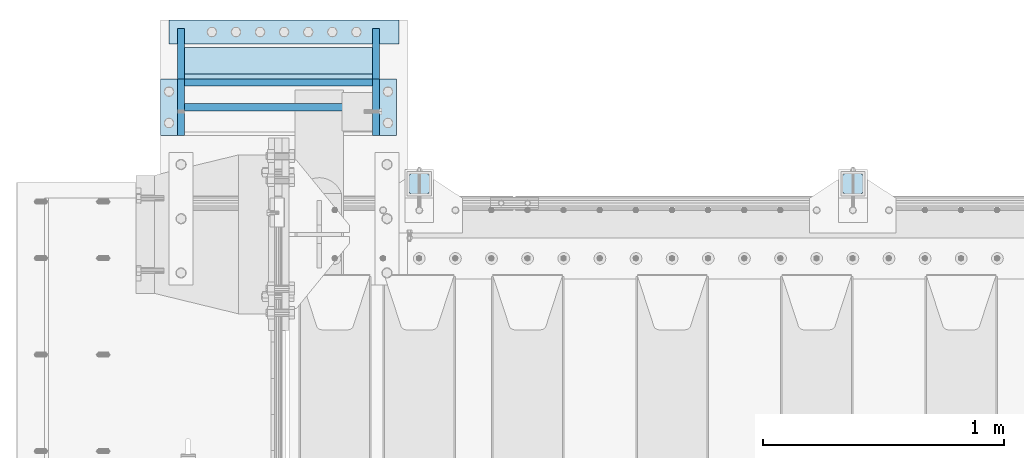
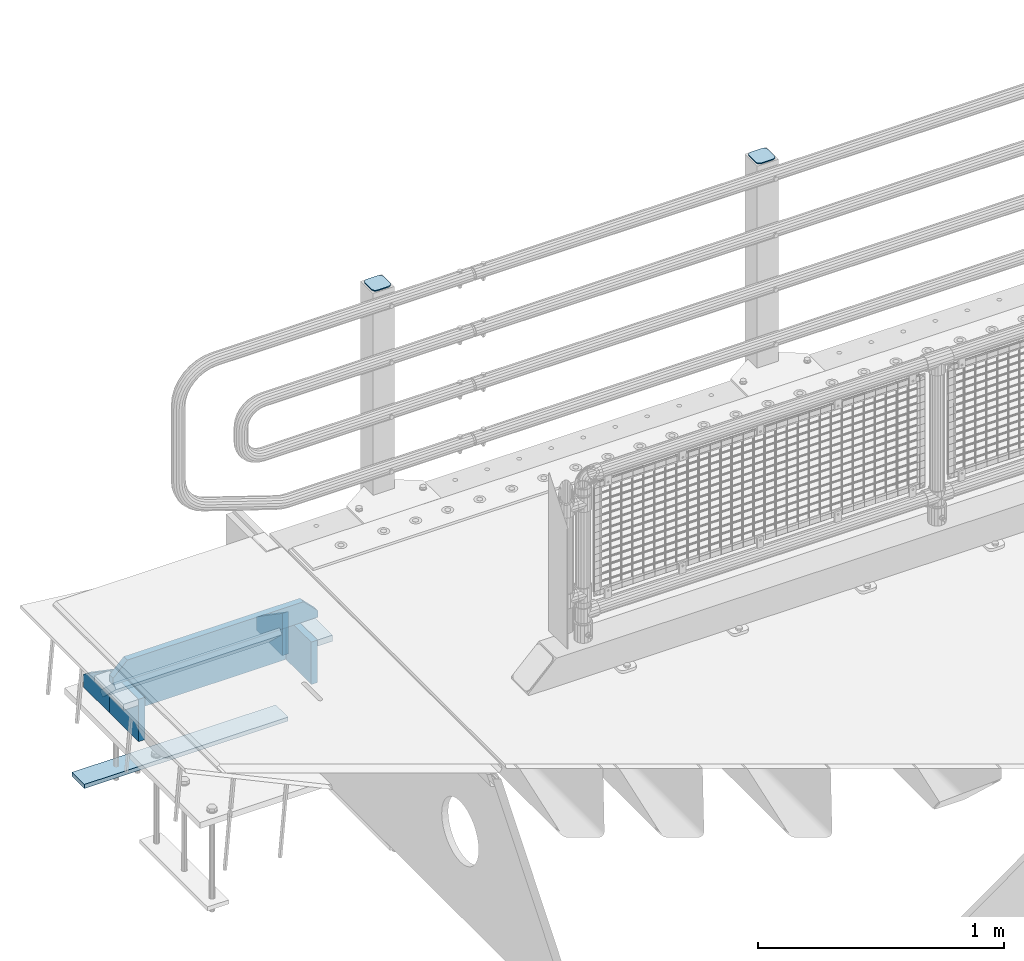
# One storey, part 195 of 219: 12 plates.
"""IFC2X3 building model written with IfcOpenShell, lengths in millimetres."""

import ifcopenshell
import ifcopenshell.guid

model = None  # the IFC model being written
_history = None  # IfcOwnerHistory: only IFC2X3 demands one
_inside = {}  # id of a spatial element -> (the spatial element, [elements in it])
_under = {}  # id of a project, library or spatial element -> (it, [spatial elements below it])
_declared = {}  # id of a project -> (the project, [libraries it declares])
_typed = {}  # id of a type object -> (the type object, [elements of that type])
_made_of = {}  # id of a material, layer set ... -> (it, [elements and type objects made of it])


def new_model(schema):
    """Start an empty IFC model of exactly this schema.

    Asked for "IFC4X3", IfcOpenShell would pick the latest addendum, in which some entities
    have other attributes; the version numbers below select the first issue.
    IFC2X3 requires an IfcOwnerHistory on every rooted entity: one is made here for all.
    """
    global model, _history
    if schema == "IFC4X3":
        model = ifcopenshell.file(schema_version=(4, 3, 0, 0))
    else:
        model = ifcopenshell.file(schema=schema)
    _inside.clear()
    _under.clear()
    _declared.clear()
    _typed.clear()
    _made_of.clear()
    _history = None
    if model.schema == "IFC2X3":
        org = make("IfcOrganization", Name="unknown")
        user = make(
            "IfcPersonAndOrganization",
            ThePerson=make("IfcPerson", FamilyName="unknown"),
            TheOrganization=org,
        )
        app = make(
            "IfcApplication",
            ApplicationDeveloper=org,
            Version="unknown",
            ApplicationFullName="unknown",
            ApplicationIdentifier="unknown",
        )
        _history = make(
            "IfcOwnerHistory",
            OwningUser=user,
            OwningApplication=app,
            ChangeAction="ADDED",
            CreationDate=0,
        )
    return model


def make(cls, **values):
    """One entity of the class cls with the attributes given. An attribute that is None is left unset."""
    return model.create_entity(
        cls, **{name: value for name, value in values.items() if value is not None}
    )


def rooted(cls, **values):
    """An entity with a GlobalId (a new one), such as an element, a storey or a relation."""
    return make(cls, GlobalId=ifcopenshell.guid.new(), OwnerHistory=_history, **values)


def si_unit(unit_type, name, prefix=None):
    """IfcSIUnit, for example si_unit("LENGTHUNIT", "METRE", prefix="MILLI")."""
    return make("IfcSIUnit", UnitType=unit_type, Prefix=prefix, Name=name)


def assignment(units):
    """IfcUnitAssignment: the units of a project."""
    return None if units is None else make("IfcUnitAssignment", Units=units)


def point(xyz):
    """IfcCartesianPoint."""
    return None if xyz is None else make("IfcCartesianPoint", Coordinates=xyz)


def direction(xyz):
    """IfcDirection."""
    return None if xyz is None else make("IfcDirection", DirectionRatios=xyz)


def frame(location, z_axis=None, x_axis=None):
    """IfcAxis2Placement3D, a coordinate frame: its origin and axes. An axis left out is left unset."""
    return make(
        "IfcAxis2Placement3D",
        Location=point(location),
        Axis=direction(z_axis),
        RefDirection=direction(x_axis),
    )


def origin_with_axes():
    """The frame at (0, 0, 0) with the z axis (0, 0, 1) and the x axis (1, 0, 0) written out."""
    return frame((0.0, 0.0, 0.0), z_axis=(0.0, 0.0, 1.0), x_axis=(1.0, 0.0, 0.0))


def place(relative_to, where):
    """IfcLocalPlacement: puts the frame where relative to a parent placement (None: the world)."""
    return make(
        "IfcLocalPlacement", PlacementRelTo=relative_to, RelativePlacement=where
    )


def context(
    kind, dimensions, precision=None, world=None, true_north=None, identifier=None
):
    """IfcGeometricRepresentationContext, for example the 3D "Model" context."""
    return make(
        "IfcGeometricRepresentationContext",
        ContextIdentifier=identifier,
        ContextType=kind,
        CoordinateSpaceDimension=dimensions,
        Precision=precision,
        WorldCoordinateSystem=world,
        TrueNorth=true_north,
    )


def subcontext(parent, identifier, kind, view, scale=None):
    """IfcGeometricRepresentationSubContext, for example "Body" below "Model"."""
    return make(
        "IfcGeometricRepresentationSubContext",
        ContextIdentifier=identifier,
        ContextType=kind,
        ParentContext=parent,
        TargetScale=scale,
        TargetView=view,
    )


def project(units=None, contexts=None):
    """IfcProject with its units and contexts."""
    return rooted(
        "IfcProject",
        Name="project",
        RepresentationContexts=contexts,
        UnitsInContext=assignment(units),
    )


def spatial(cls, under=None, at=None, **own):
    """A site, building, storey or space (cls), placed at a placement, below another one or the project."""
    s = rooted(cls, ObjectPlacement=at, **own)
    if under is not None:
        _under.setdefault(under.id(), (under, []))[1].append(s)
    return s


def faces_of(points, faces, orient=None, outer=None):
    """IfcFace entities. A face is a list of loops; a loop is a list of indices into points, from 0.

    orient and outer hold one flag for each loop. By default every Orientation is true, the
    first loop of a face is its IfcFaceOuterBound and the others are IfcFaceBound.
    """
    made = []
    for i, loops in enumerate(faces):
        bounds = []
        for j, loop in enumerate(loops):
            is_outer = j == 0 if outer is None else outer[i][j]
            bounds.append(
                make(
                    "IfcFaceOuterBound" if is_outer else "IfcFaceBound",
                    Bound=make("IfcPolyLoop", Polygon=[points[k] for k in loop]),
                    Orientation=True if orient is None else orient[i][j],
                )
            )
        made.append(make("IfcFace", Bounds=bounds))
    return made


def faceted_brep(points, faces, orient=None, outer=None, voids=None):
    """IfcFacetedBrep: a solid bounded by flat faces; with voids (closed shells), ...WithVoids."""
    shared = [point(p) for p in points]
    hull = make("IfcClosedShell", CfsFaces=faces_of(shared, faces, orient, outer))
    if voids is None:
        return make("IfcFacetedBrep", Outer=hull)
    return make(
        "IfcFacetedBrepWithVoids",
        Outer=hull,
        Voids=[
            make(cls, CfsFaces=faces_of(shared, fs, o, b)) for cls, fs, o, b in voids
        ],
    )


def shape(context_of_items, identifier, shape_type, items):
    """IfcShapeRepresentation: the items that make up one representation, for example the "Body"."""
    return make(
        "IfcShapeRepresentation",
        ContextOfItems=context_of_items,
        RepresentationIdentifier=identifier,
        RepresentationType=shape_type,
        Items=items,
    )


def material(Name=None, Category=None):
    """IfcMaterial."""
    return make("IfcMaterial", Name=Name, Category=Category)


def made_of(thing, what):
    """Note that an element or type object is made of a material, layer set ...; save() writes the relation."""
    if what is not None:
        _made_of.setdefault(what.id(), (what, []))[1].append(thing)
    return thing


def type_object(cls, material=None, **own):
    """A type object (cls), such as IfcWallType, which elements share."""
    return made_of(rooted(cls, **own), material)


def element(
    cls,
    number,
    at=None,
    inside=None,
    cuts=None,
    type_object=None,
    material=None,
    context=None,
    identifier="Body",
    shape_type=None,
    held_by="IfcProductDefinitionShape",
    body=None,
    shapes=None,
    **own,
):
    """One element of the class cls, such as IfcWall. Its Tag is "e" and its number.

    at: its placement. inside: the storey or other place that contains it. cuts: it is an
    opening in that element (IfcRelVoidsElement). A single representation is given by context,
    identifier, shape_type and body (its items); several are given by shapes. held_by: the class
    of the entity that holds the representations. save() writes the other relations.
    """
    e = rooted(cls, Tag="e%d" % number, ObjectPlacement=at, **own)
    if body is not None:
        shapes = [shape(context, identifier, shape_type, body)]
    if shapes is not None:
        e.Representation = make(held_by, Representations=shapes)
    if inside is not None:
        _inside.setdefault(inside.id(), (inside, []))[1].append(e)
    if cuts is not None:
        rooted(
            "IfcRelVoidsElement", RelatingBuildingElement=cuts, RelatedOpeningElement=e
        )
    if type_object is not None:
        _typed.setdefault(type_object.id(), (type_object, []))[1].append(e)
    return made_of(e, material)


def aggregate(whole, parts):
    """IfcRelAggregates: a whole, such as a stair, and the parts it consists of."""
    return rooted("IfcRelAggregates", RelatingObject=whole, RelatedObjects=parts)


def save(model, path):
    """Write the relations noted so far, then the file.

    IfcRelAggregates (storeys below a building ...), IfcRelContainedInSpatialStructure (elements
    in a storey), IfcRelDefinesByType, IfcRelAssociatesMaterial and IfcRelDeclares: one each for
    every whole, place, type object, material and project.
    """
    for whole, parts in _under.values():
        aggregate(whole, parts)
    for where, things in _inside.values():
        rooted(
            "IfcRelContainedInSpatialStructure",
            RelatedElements=things,
            RelatingStructure=where,
        )
    for kind, things in _typed.values():
        rooted("IfcRelDefinesByType", RelatedObjects=things, RelatingType=kind)
    for what, things in _made_of.values():
        rooted("IfcRelAssociatesMaterial", RelatedObjects=things, RelatingMaterial=what)
    for by, libraries in _declared.values():
        rooted("IfcRelDeclares", RelatingContext=by, RelatedDefinitions=libraries)
    model.write(path)


model = new_model("IFC2X3")

# Units and contexts
model_context = context("Model", 3, precision=1e-05, world=origin_with_axes())
body_context = subcontext(model_context, "Body", "Model", "MODEL_VIEW")
ifc_project = project(units=[si_unit("LENGTHUNIT", "METRE", prefix="MILLI"), si_unit("AREAUNIT", "SQUARE_METRE"), si_unit("VOLUMEUNIT", "CUBIC_METRE"), si_unit("MASSUNIT", "GRAM", prefix="KILO"), si_unit("TIMEUNIT", "SECOND"), si_unit("PLANEANGLEUNIT", "RADIAN"), si_unit("SOLIDANGLEUNIT", "STERADIAN"), si_unit("THERMODYNAMICTEMPERATUREUNIT", "DEGREE_CELSIUS"), si_unit("LUMINOUSINTENSITYUNIT", "LUMEN")], contexts=[model_context])

# Site, building, storey
site_placement = place(None, origin_with_axes())
site = spatial("IfcSite", under=ifc_project, at=site_placement, CompositionType="ELEMENT")
building_placement = place(site_placement, origin_with_axes())
building = spatial("IfcBuilding", under=site, at=building_placement, Name="Standard", CompositionType="ELEMENT")
storey_placement = place(building_placement, origin_with_axes())
storey = spatial("IfcBuildingStorey", under=building, at=storey_placement, Name="Undefined", CompositionType="ELEMENT", Elevation=0.0)

# Plates
ifc_material_1 = material(Name="STEEL/S355J2")
plate_type_1 = type_object("IfcPlateType", PredefinedType="NOTDEFINED")
plate_1_placement = place(storey_placement, frame((2394.00000000013, 33166.0000000002, 1012.50000000001), z_axis=(0.0, 1.0, 0.0), x_axis=(-1.0, 0.0, 0.0)))
element("IfcPlate", 1, at=plate_1_placement, inside=storey, type_object=plate_type_1, material=ifc_material_1, context=body_context, shape_type="Brep", body=[
    faceted_brep([(0.0, -2.5, 19.0), (0.0, -2.5, 69.0), (0.0, 2.5, 69.0), (0.0, 2.5, 19.0), (0.476369668545885, -2.5, 73.2278977451715), (0.476369668545885, 2.5, 73.2278977451715), (1.88159150985484, -2.5, 77.2437910432345), (1.88159150985484, 2.5, 77.2437910432345), (4.14520183310742, -2.5, 80.8463062353185), (4.14520183310742, 2.5, 80.8463062353185), (7.15369376468334, -2.5, 83.8547981668889), (7.15369376468334, 2.5, 83.8547981668889), (10.7562089567673, -2.5, 86.118408490147), (10.7562089567673, 2.5, 86.118408490147), (14.7721022548303, -2.5, 87.5236303314523), (14.7721022548303, 2.5, 87.5236303314523), (19.0, -2.5, 88.0), (19.0, 2.5, 88.0), (69.0, -2.5, 88.0), (69.0, 2.5, 88.0), (73.2278977451697, -2.5, 87.5236303314523), (73.2278977451697, 2.5, 87.5236303314523), (77.2437910432327, -2.5, 86.118408490147), (77.2437910432327, 2.5, 86.118408490147), (80.8463062353167, -2.5, 83.8547981668889), (80.8463062353167, 2.5, 83.8547981668889), (83.8547981668926, -2.5, 80.8463062353185), (83.8547981668926, 2.5, 80.8463062353185), (86.1184084901452, -2.5, 77.2437910432345), (86.1184084901452, 2.5, 77.2437910432345), (87.5236303314541, -2.5, 73.2278977451715), (87.5236303314541, 2.5, 73.2278977451715), (88.0, -2.5, 69.0), (88.0, 2.5, 69.0), (88.0, -2.5, 19.0), (88.0, 2.5, 19.0), (87.5236303314541, -2.5, 14.7721022548285), (87.5236303314541, 2.5, 14.7721022548285), (86.1184084901452, -2.5, 10.7562089567655), (86.1184084901452, 2.5, 10.7562089567655), (83.8547981668926, -2.5, 7.15369376468152), (83.8547981668926, 2.5, 7.15369376468152), (80.8463062353167, -2.5, 4.14520183311106), (80.8463062353167, 2.5, 4.14520183311106), (77.2437910432345, -2.5, 1.88159150985302), (77.2437910432345, 2.5, 1.88159150985302), (73.2278977451697, -2.5, 0.476369668547704), (73.2278977451697, 2.5, 0.476369668547704), (69.0, -2.5, 0.0), (69.0, 2.5, 0.0), (19.0, -2.5, 0.0), (19.0, 2.5, 0.0), (14.7721022548303, -2.5, 0.476369668547704), (14.7721022548303, 2.5, 0.476369668547704), (10.7562089567673, -2.5, 1.88159150985302), (10.7562089567673, 2.5, 1.88159150985302), (7.15369376468334, -2.5, 4.14520183311106), (7.15369376468334, 2.5, 4.14520183311106), (4.14520183310742, -2.5, 7.15369376468152), (4.14520183310742, 2.5, 7.15369376468152), (1.88159150985484, -2.5, 10.7562089567655), (1.88159150985484, 2.5, 10.7562089567655), (0.476369668545885, -2.5, 14.7721022548285), (0.476369668545885, 2.5, 14.7721022548285)], [[[0, 1, 2, 3]], [[1, 4, 5, 2]], [[4, 6, 7, 5]], [[6, 8, 9, 7]], [[8, 10, 11, 9]], [[10, 12, 13, 11]], [[12, 14, 15, 13]], [[14, 16, 17, 15]], [[16, 18, 19, 17]], [[18, 20, 21, 19]], [[20, 22, 23, 21]], [[22, 24, 25, 23]], [[24, 26, 27, 25]], [[26, 28, 29, 27]], [[28, 30, 31, 29]], [[30, 32, 33, 31]], [[32, 34, 35, 33]], [[34, 36, 37, 35]], [[36, 38, 39, 37]], [[38, 40, 41, 39]], [[40, 42, 43, 41]], [[42, 44, 45, 43]], [[44, 46, 47, 45]], [[46, 48, 49, 47]], [[48, 50, 51, 49]], [[50, 52, 53, 51]], [[52, 54, 55, 53]], [[54, 56, 57, 55]], [[56, 58, 59, 57]], [[58, 60, 61, 59]], [[60, 62, 63, 61]], [[62, 0, 3, 63]], [[5, 7, 9, 11, 13, 15, 17, 19, 21, 23, 25, 27, 29, 31, 33, 35, 37, 39, 41, 43, 45, 47, 49, 51, 53, 55, 57, 59, 61, 63, 3, 2]], [[62, 60, 58, 56, 54, 52, 50, 48, 46, 44, 42, 40, 38, 36, 34, 32, 30, 28, 26, 24, 22, 20, 18, 16, 14, 12, 10, 8, 6, 4, 1, 0]]]),
])
plate_2_placement = place(storey_placement, frame((594.000000000131, 33166.0000000002, 1012.50000000001), z_axis=(0.0, 1.0, 0.0), x_axis=(-1.0, 0.0, 0.0)))
element("IfcPlate", 2, at=plate_2_placement, inside=storey, type_object=plate_type_1, material=ifc_material_1, context=body_context, shape_type="Brep", body=[
    faceted_brep([(0.0, -2.5, 19.0), (0.0, -2.5, 69.0), (0.0, 2.5, 69.0), (0.0, 2.5, 19.0), (0.476369668545885, -2.5, 73.2278977451715), (0.476369668545885, 2.5, 73.2278977451715), (1.88159150985484, -2.5, 77.2437910432345), (1.88159150985484, 2.5, 77.2437910432345), (4.14520183310742, -2.5, 80.8463062353185), (4.14520183310742, 2.5, 80.8463062353185), (7.15369376468334, -2.5, 83.8547981668889), (7.15369376468334, 2.5, 83.8547981668889), (10.7562089567673, -2.5, 86.118408490147), (10.7562089567673, 2.5, 86.118408490147), (14.7721022548303, -2.5, 87.5236303314523), (14.7721022548303, 2.5, 87.5236303314523), (19.0, -2.5, 88.0), (19.0, 2.5, 88.0), (69.0, -2.5, 88.0), (69.0, 2.5, 88.0), (73.2278977451697, -2.5, 87.5236303314523), (73.2278977451697, 2.5, 87.5236303314523), (77.2437910432327, -2.5, 86.118408490147), (77.2437910432327, 2.5, 86.118408490147), (80.8463062353167, -2.5, 83.8547981668889), (80.8463062353167, 2.5, 83.8547981668889), (83.8547981668926, -2.5, 80.8463062353185), (83.8547981668926, 2.5, 80.8463062353185), (86.1184084901452, -2.5, 77.2437910432345), (86.1184084901452, 2.5, 77.2437910432345), (87.5236303314541, -2.5, 73.2278977451715), (87.5236303314541, 2.5, 73.2278977451715), (88.0, -2.5, 69.0), (88.0, 2.5, 69.0), (88.0, -2.5, 19.0), (88.0, 2.5, 19.0), (87.5236303314541, -2.5, 14.7721022548285), (87.5236303314541, 2.5, 14.7721022548285), (86.1184084901452, -2.5, 10.7562089567655), (86.1184084901452, 2.5, 10.7562089567655), (83.8547981668926, -2.5, 7.15369376468152), (83.8547981668926, 2.5, 7.15369376468152), (80.8463062353167, -2.5, 4.14520183311106), (80.8463062353167, 2.5, 4.14520183311106), (77.2437910432345, -2.5, 1.88159150985302), (77.2437910432345, 2.5, 1.88159150985302), (73.2278977451697, -2.5, 0.476369668547704), (73.2278977451697, 2.5, 0.476369668547704), (69.0, -2.5, 0.0), (69.0, 2.5, 0.0), (19.0, -2.5, 0.0), (19.0, 2.5, 0.0), (14.7721022548303, -2.5, 0.476369668547704), (14.7721022548303, 2.5, 0.476369668547704), (10.7562089567673, -2.5, 1.88159150985302), (10.7562089567673, 2.5, 1.88159150985302), (7.15369376468334, -2.5, 4.14520183311106), (7.15369376468334, 2.5, 4.14520183311106), (4.14520183310742, -2.5, 7.15369376468152), (4.14520183310742, 2.5, 7.15369376468152), (1.88159150985484, -2.5, 10.7562089567655), (1.88159150985484, 2.5, 10.7562089567655), (0.476369668545885, -2.5, 14.7721022548285), (0.476369668545885, 2.5, 14.7721022548285)], [[[0, 1, 2, 3]], [[1, 4, 5, 2]], [[4, 6, 7, 5]], [[6, 8, 9, 7]], [[8, 10, 11, 9]], [[10, 12, 13, 11]], [[12, 14, 15, 13]], [[14, 16, 17, 15]], [[16, 18, 19, 17]], [[18, 20, 21, 19]], [[20, 22, 23, 21]], [[22, 24, 25, 23]], [[24, 26, 27, 25]], [[26, 28, 29, 27]], [[28, 30, 31, 29]], [[30, 32, 33, 31]], [[32, 34, 35, 33]], [[34, 36, 37, 35]], [[36, 38, 39, 37]], [[38, 40, 41, 39]], [[40, 42, 43, 41]], [[42, 44, 45, 43]], [[44, 46, 47, 45]], [[46, 48, 49, 47]], [[48, 50, 51, 49]], [[50, 52, 53, 51]], [[52, 54, 55, 53]], [[54, 56, 57, 55]], [[56, 58, 59, 57]], [[58, 60, 61, 59]], [[60, 62, 63, 61]], [[62, 0, 3, 63]], [[5, 7, 9, 11, 13, 15, 17, 19, 21, 23, 25, 27, 29, 31, 33, 35, 37, 39, 41, 43, 45, 47, 49, 51, 53, 55, 57, 59, 61, 63, 3, 2]], [[62, 60, 58, 56, 54, 52, 50, 48, 46, 44, 42, 40, 38, 36, 34, 32, 30, 28, 26, 24, 22, 20, 18, 16, 14, 12, 10, 8, 6, 4, 1, 0]]]),
])
ifc_material_2 = material(Name="STEEL/S355N")
plate_type_2 = type_object("IfcPlateType", PredefinedType="NOTDEFINED")
plate_3_placement = place(storey_placement, frame((355.000000000016, 33765.3571347532, -1017.14966545659), z_axis=(-1.0, 0.0, 0.0), x_axis=(0.0, -0.723355636225724, 0.690475650215472)))
element("IfcPlate", 3, at=plate_3_placement, inside=storey, type_object=plate_type_2, material=ifc_material_2, context=body_context, shape_type="Brep", body=[
    faceted_brep([(0.0, -15.0, 0.0), (0.0, -15.0000000000036, 779.0), (-3.63797880709171e-12, 15.0000000000036, 779.0), (0.0, 15.0, 0.0), (152.069061279293, -14.9999999999964, 779.0), (152.069061279297, 15.0, 779.0), (152.069061279293, -14.9999999999964, 0.0), (152.069061279297, 15.0, 0.0)], [[[0, 1, 2, 3]], [[1, 4, 5, 2]], [[4, 6, 7, 5]], [[6, 0, 3, 7]], [[5, 7, 3, 2]], [[6, 4, 1, 0]]]),
])
plate_type_3 = type_object("IfcPlateType", PredefinedType="NOTDEFINED")
plate_4_placement = place(storey_placement, frame((-488.999999999987, 33889.9999985338, -1468.0), z_axis=(0.0, -1.0, 0.0), x_axis=(1.0, 0.0, 0.0)))
element("IfcPlate", 4, at=plate_4_placement, inside=storey, type_object=plate_type_3, material=ifc_material_2, context=body_context, shape_type="Brep", body=[
    faceted_brep([(0.0, -10.0, 0.0), (0.0, -10.0, 100.0), (0.0, 10.0, 100.0), (0.0, 10.0, 0.0), (955.0, -10.0, 100.0), (955.0, 10.0, 100.0), (955.0, -10.0, 0.0), (955.0, 10.0, 0.0)], [[[0, 1, 2, 3]], [[1, 4, 5, 2]], [[4, 6, 7, 5]], [[6, 0, 3, 7]], [[5, 7, 3, 2]], [[6, 4, 1, 0]]]),
])
plate_type_4 = type_object("IfcPlateType", PredefinedType="NOTDEFINED")
for number, where, z_axis, x_axis in (
    (5, (370.000000000015, 33855.0, -1028.0), (0.0, 0.0, 1.0), (0.0, -1.0, 0.0)),
    (6, (-438.999999999989, 33855.0, -1028.0), (0.0, 0.0, 1.0), (0.0, -1.0, 0.0)),
):
    element("IfcPlate", number, at=place(storey_placement, frame(where, z_axis=z_axis, x_axis=x_axis)), inside=storey, type_object=plate_type_4, material=ifc_material_2, context=body_context, shape_type="Brep", body=[
        faceted_brep([(0.0, -15.0, 0.0), (0.0, -15.0, 66.0), (0.0, 15.0, 66.0), (0.0, 15.0, 0.0), (210.0, -15.0, 210.0), (210.0, 15.0, 210.0), (210.0, -15.0, 0.0), (210.0, 15.0, 0.0)], [[[0, 1, 2, 3]], [[1, 4, 5, 2]], [[4, 6, 7, 5]], [[6, 0, 3, 7]], [[5, 7, 3, 2]], [[6, 4, 1, 0]]]),
    ])
plate_5_placement = place(storey_placement, frame((370.000000000015, 33410.0, -818.000000000005), z_axis=(0.0, 0.0, -1.0), x_axis=(0.0, 1.0, 0.0)))
element("IfcPlate", 7, at=plate_5_placement, inside=storey, type_object=plate_type_4, material=ifc_material_2, context=body_context, shape_type="Brep", body=[
    faceted_brep([(0.0, -15.0, 0.0), (0.0, -15.0, 210.0), (0.0, 15.0, 210.0), (0.0, 15.0, 0.0), (235.0, -15.0, 210.0), (235.0, 15.0, 210.0), (235.0, -15.0, 0.0), (235.0, 15.0, 0.0)], [[[0, 1, 2, 3]], [[1, 4, 5, 2]], [[4, 6, 7, 5]], [[6, 0, 3, 7]], [[5, 7, 3, 2]], [[6, 4, 1, 0]]]),
])
plate_6_placement = place(storey_placement, frame((-423.999999999985, 33630.0, -1028.0), z_axis=(1.0, 0.0, 0.0), x_axis=(0.0, 0.0, 1.0)))
element("IfcPlate", 8, at=plate_6_placement, inside=storey, type_object=plate_type_4, material=ifc_material_2, context=body_context, shape_type="Brep", body=[
    faceted_brep([(0.0, -15.0, 0.0), (0.0, -15.0000000000036, 779.0), (-3.63797880709171e-12, 15.0000000000036, 779.0), (0.0, 15.0, 0.0), (210.0, -15.0, 779.0), (210.0, 15.0, 779.0), (210.0, -15.0, 0.0), (210.0, 15.0, 0.0)], [[[0, 1, 2, 3]], [[1, 4, 5, 2]], [[4, 6, 7, 5]], [[6, 0, 3, 7]], [[5, 7, 3, 2]], [[6, 4, 1, 0]]]),
])
plate_7_placement = place(storey_placement, frame((-438.999999999985, 33410.0, -818.000000000004), z_axis=(0.0, 0.0, -1.0), x_axis=(0.0, 1.0, 0.0)))
element("IfcPlate", 9, at=plate_7_placement, inside=storey, type_object=plate_type_4, material=ifc_material_2, context=body_context, shape_type="Brep", body=[
    faceted_brep([(0.0, -15.0, 0.0), (0.0, -15.0, 210.0), (0.0, 15.0, 210.0), (0.0, 15.0, 0.0), (235.0, -15.0, 210.0), (235.0, 15.0, 210.0), (235.0, -15.0, 0.0), (235.0, 15.0, 0.0)], [[[0, 1, 2, 3]], [[1, 4, 5, 2]], [[4, 6, 7, 5]], [[6, 0, 3, 7]], [[5, 7, 3, 2]], [[6, 4, 1, 0]]]),
])
plate_type_5 = type_object("IfcPlateType", PredefinedType="NOTDEFINED")
plate_8_placement = place(storey_placement, frame((-513.999999999992, 33527.5, -788.000000000004), z_axis=(0.0, 0.0, 1.0), x_axis=(1.0, 0.0, 0.0)))
element("IfcPlate", 10, at=plate_8_placement, inside=storey, type_object=plate_type_5, material=ifc_material_2, context=body_context, shape_type="Brep", body=[
    faceted_brep([(0.0, -15.0, 0.0), (0.0, -15.0, 33.0), (0.0, 15.0, 33.0), (0.0, 15.0, 0.0), (67.0, -15.0, 100.0), (67.0, 15.0, 100.0), (892.0, -15.0, 100.0), (892.0, 15.0, 100.0), (959.0, -15.0, 33.0), (959.0, 15.0, 33.0), (959.0, -15.0, 0.0), (959.0, 15.0, 0.0)], [[[0, 1, 2, 3]], [[1, 4, 5, 2]], [[4, 6, 7, 5]], [[6, 8, 9, 7]], [[8, 10, 11, 9]], [[10, 0, 3, 11]], [[5, 7, 9, 11, 3, 2]], [[10, 8, 6, 4, 1, 0]]]),
])
plate_type_6 = type_object("IfcPlateType", PredefinedType="NOTDEFINED")
for number, where, z_axis, x_axis in (
    (11, (385.000000000015, 33645.0, -833.000000000004), (1.0, 0.0, 0.0), (0.0, -1.0, 0.0)),
    (12, (-523.999999999985, 33645.0, -833.000000000004), (1.0, 0.0, 0.0), (0.0, -1.0, 0.0)),
):
    element("IfcPlate", number, at=place(storey_placement, frame(where, z_axis=z_axis, x_axis=x_axis)), inside=storey, type_object=plate_type_6, material=ifc_material_2, context=body_context, shape_type="Brep", body=[
        faceted_brep([(0.0, -15.0, 0.0), (0.0, -15.0, 70.0), (0.0, 15.0, 70.0), (0.0, 15.0, 0.0), (235.0, -15.0, 70.0), (235.0, 15.0, 70.0), (235.0, -15.0, 0.0), (235.0, 15.0, 0.0)], [[[0, 1, 2, 3]], [[1, 4, 5, 2]], [[4, 6, 7, 5]], [[6, 0, 3, 7]], [[5, 7, 3, 2]], [[6, 4, 1, 0]]]),
    ])

save(model, "model.ifc")
